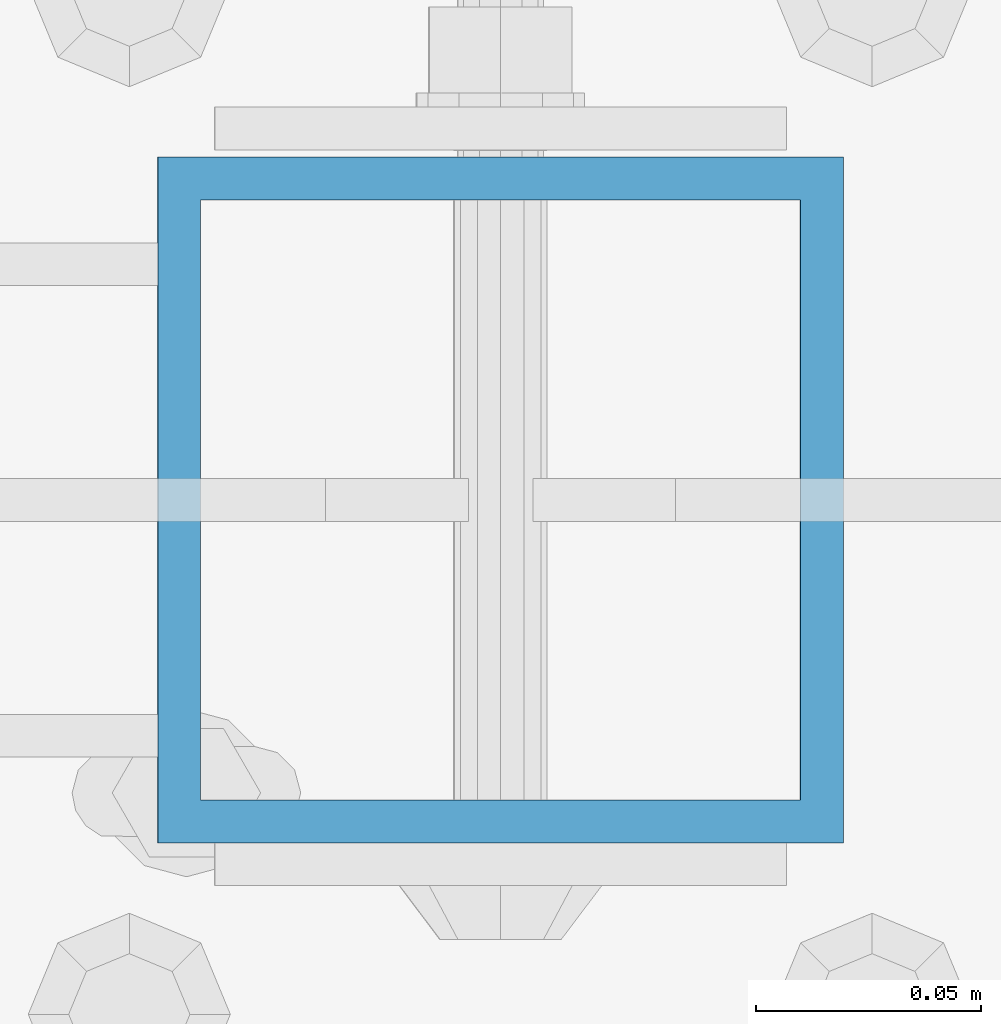
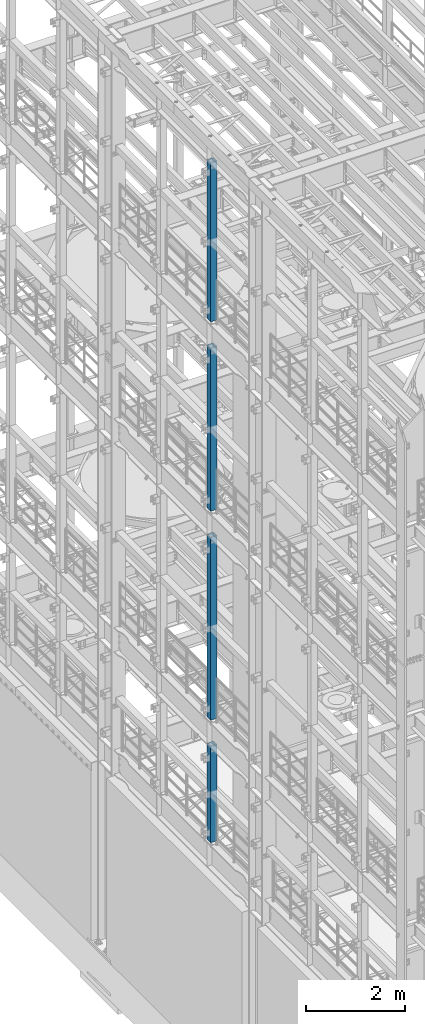
# One storey, part 697 of 1876: 4 columns, 4 elements without a shape of their own.
"""IFC2X3 building model written with IfcOpenShell, lengths in millimetres."""

from ifc_helpers import new_model, si_unit, frame, origin_with_axes, place, context, subcontext, project, spatial, faceted_brep, material, type_object, element, aggregate, save


model = new_model("IFC2X3")

# Units and contexts
model_context = context("Model", 3, precision=1e-05, world=origin_with_axes())
body_context = subcontext(model_context, "Body", "Model", "MODEL_VIEW")
ifc_project = project(units=[si_unit("LENGTHUNIT", "METRE", prefix="MILLI"), si_unit("AREAUNIT", "SQUARE_METRE"), si_unit("VOLUMEUNIT", "CUBIC_METRE"), si_unit("MASSUNIT", "GRAM", prefix="KILO"), si_unit("TIMEUNIT", "SECOND"), si_unit("PLANEANGLEUNIT", "RADIAN"), si_unit("SOLIDANGLEUNIT", "STERADIAN"), si_unit("THERMODYNAMICTEMPERATUREUNIT", "DEGREE_CELSIUS"), si_unit("LUMINOUSINTENSITYUNIT", "LUMEN")], contexts=[model_context])

# Site, building, storey
site_placement = place(None, origin_with_axes())
site = spatial("IfcSite", under=ifc_project, at=site_placement, CompositionType="ELEMENT")
building_placement = place(site_placement, origin_with_axes())
building = spatial("IfcBuilding", under=site, at=building_placement, Name="Undefined", CompositionType="ELEMENT")
storey_placement = place(building_placement, origin_with_axes())
storey = spatial("IfcBuildingStorey", under=building, at=storey_placement, Name="Undefined", CompositionType="ELEMENT", Elevation=0.0)

# Assembly, column
assembly_1_placement = place(storey_placement, origin_with_axes())
assembly_1 = element("IfcElementAssembly", 1, at=assembly_1_placement, inside=storey, Name="BEAM", AssemblyPlace="NOTDEFINED", PredefinedType="RIGID_FRAME")
ifc_material = material()
column_type = type_object("IfcColumnType", Name="HSS6X6X3/8", PredefinedType="NOTDEFINED")
column_1_placement = place(assembly_1_placement, frame((0.0, 3556.0, 17983.2), z_axis=(-1.0, 0.0, 0.0), x_axis=(0.0, 0.0, 1.0)))
column_1 = element("IfcColumn", 2, at=column_1_placement, type_object=column_type, material=ifc_material, Name="COLUMN", ObjectType="HSS6X6X3/8", context=body_context, shape_type="Brep", body=[
    faceted_brep([(12.7000000000016, 66.6750000000002, -66.6750000000002), (12.7000000000016, -66.6750000000002, -66.6750000000002), (3937.0, -66.6750000000002, -66.675), (3937.0, 66.6750000000002, -66.675), (12.7000000000016, -66.6750000000002, 66.6750000000002), (3937.0, -66.6750000000002, 66.675), (12.7000000000016, 66.6750000000002, 66.6750000000002), (3937.0, 66.6750000000002, 66.675), (12.7000000000016, 76.1999999999998, -76.1999999999998), (12.7000000000016, 76.1999999999998, 76.1999999999998), (3937.0, 76.1999999999998, 76.2), (3937.0, 76.1999999999998, -76.2), (12.7000000000016, -76.1999999999998, 76.1999999999998), (3937.0, -76.1999999999998, 76.2), (12.7000000000016, -76.1999999999998, -76.1999999999998), (3937.0, -76.1999999999998, -76.2)], [[[0, 1, 2, 3]], [[1, 4, 5, 2]], [[4, 6, 7, 5]], [[6, 0, 3, 7]], [[8, 9, 10, 11]], [[9, 12, 13, 10]], [[12, 14, 15, 13]], [[14, 8, 11, 15]], [[13, 15, 11, 10], [5, 7, 3, 2]], [[14, 12, 9, 8], [6, 4, 1, 0]]]),
])
aggregate(assembly_1, [column_1])

assembly_2_placement = place(storey_placement, origin_with_axes())
assembly_2 = element("IfcElementAssembly", 3, at=assembly_2_placement, inside=storey, Name="BEAM", AssemblyPlace="NOTDEFINED", PredefinedType="RIGID_FRAME")
column_2_placement = place(assembly_2_placement, frame((0.0, 3556.0, 13309.6), z_axis=(-1.0, 0.0, 0.0), x_axis=(0.0, 0.0, 1.0)))
column_2 = element("IfcColumn", 4, at=column_2_placement, type_object=column_type, material=ifc_material, Name="COLUMN", ObjectType="HSS6X6X3/8", context=body_context, shape_type="Brep", body=[
    faceted_brep([(12.7000000000016, 66.6750000000002, -66.6750000000002), (12.7000000000016, -66.6750000000002, -66.6750000000002), (4038.6, -66.6750000000002, -66.675), (4038.6, 66.6750000000002, -66.675), (12.7000000000016, -66.6750000000002, 66.6750000000002), (4038.6, -66.6750000000002, 66.675), (12.7000000000016, 66.6750000000002, 66.6750000000002), (4038.6, 66.6750000000002, 66.675), (12.7000000000016, 76.1999999999998, -76.1999999999998), (12.7000000000016, 76.1999999999998, 76.1999999999998), (4038.6, 76.1999999999998, 76.2), (4038.6, 76.1999999999998, -76.2), (12.7000000000016, -76.1999999999998, 76.1999999999998), (4038.6, -76.1999999999998, 76.2), (12.7000000000016, -76.1999999999998, -76.1999999999998), (4038.6, -76.1999999999998, -76.2)], [[[0, 1, 2, 3]], [[1, 4, 5, 2]], [[4, 6, 7, 5]], [[6, 0, 3, 7]], [[8, 9, 10, 11]], [[9, 12, 13, 10]], [[12, 14, 15, 13]], [[14, 8, 11, 15]], [[13, 15, 11, 10], [5, 7, 3, 2]], [[14, 12, 9, 8], [6, 4, 1, 0]]]),
])
aggregate(assembly_2, [column_2])

assembly_3_placement = place(storey_placement, origin_with_axes())
assembly_3 = element("IfcElementAssembly", 5, at=assembly_3_placement, inside=storey, Name="BEAM", AssemblyPlace="NOTDEFINED", PredefinedType="RIGID_FRAME")
column_3_placement = place(assembly_3_placement, frame((0.0, 3556.0, 8153.4), z_axis=(-0.999999999563517, 0.0, -2.95459999870218e-05), x_axis=(-2.95459999861759e-05, 0.0, 0.999999999563517)))
column_3 = element("IfcColumn", 6, at=column_3_placement, type_object=column_type, material=ifc_material, Name="COLUMN", ObjectType="HSS6X6X3/8", context=body_context, shape_type="Brep", body=[
    faceted_brep([(12.698030025992, 66.6750000000002, -66.675), (12.698030025992, -66.6750000000002, -66.675), (4521.2007045434, -66.6750000000002, -66.675), (4521.2007045434, 66.6750000000002, -66.675), (12.7019699850925, -66.6750000000002, 66.675), (4521.20070454334, -66.6750000000002, 66.675), (12.7019699850925, 66.6750000000002, 66.675), (4521.20070454334, 66.6750000000002, 66.675), (12.6977486003425, 76.1999999999998, -76.2), (12.7022514107421, 76.1999999999998, 76.2), (4521.20070454334, 76.1999999999998, 76.2), (4521.2007045434, 76.1999999999998, -76.2), (12.7022514107421, -76.1999999999998, 76.2), (4521.20070454334, -76.1999999999998, 76.2), (12.6977486003425, -76.1999999999998, -76.2), (4521.2007045434, -76.1999999999998, -76.2)], [[[0, 1, 2, 3]], [[1, 4, 5, 2]], [[4, 6, 7, 5]], [[6, 0, 3, 7]], [[8, 9, 10, 11]], [[9, 12, 13, 10]], [[12, 14, 15, 13]], [[14, 8, 11, 15]], [[13, 15, 11, 10], [5, 7, 3, 2]], [[14, 12, 9, 8], [6, 4, 1, 0]]]),
])
aggregate(assembly_3, [column_3])

assembly_4_placement = place(storey_placement, origin_with_axes())
assembly_4 = element("IfcElementAssembly", 7, at=assembly_4_placement, inside=storey, Name="BEAM", AssemblyPlace="NOTDEFINED", PredefinedType="RIGID_FRAME")
column_4_placement = place(assembly_4_placement, frame((0.0, 3556.0, 5130.8), z_axis=(-0.999999998434855, 0.0, -5.59490000241567e-05), x_axis=(-5.59490000243298e-05, 0.0, 0.999999998434855)))
column_4 = element("IfcColumn", 8, at=column_4_placement, type_object=column_type, material=ifc_material, Name="COLUMN", ObjectType="HSS6X6X3/8", context=body_context, shape_type="Brep", body=[
    faceted_brep([(12.6962696202891, 66.6750000000002, -66.675), (12.6962696202891, -66.6750000000002, -66.675), (2387.60070630699, -66.6750000000002, -66.675), (2387.60070630699, 66.6750000000002, -66.675), (12.7037304194646, -66.6750000000002, 66.675), (2387.600706307, -66.6750000000002, 66.675), (12.7037304194646, 66.6750000000002, 66.675), (2387.600706307, 66.6750000000002, 66.675), (12.6957367060613, 76.1999999999998, -76.2), (12.7042633336914, 76.1999999999998, 76.2), (2387.600706307, 76.1999999999998, 76.2), (2387.60070630699, 76.1999999999998, -76.2), (12.7042633336914, -76.1999999999998, 76.2), (2387.600706307, -76.1999999999998, 76.2), (12.6957367060613, -76.1999999999998, -76.2), (2387.60070630699, -76.1999999999998, -76.2)], [[[0, 1, 2, 3]], [[1, 4, 5, 2]], [[4, 6, 7, 5]], [[6, 0, 3, 7]], [[8, 9, 10, 11]], [[9, 12, 13, 10]], [[12, 14, 15, 13]], [[14, 8, 11, 15]], [[13, 15, 11, 10], [5, 7, 3, 2]], [[14, 12, 9, 8], [6, 4, 1, 0]]]),
])
aggregate(assembly_4, [column_4])

save(model, "model.ifc")
